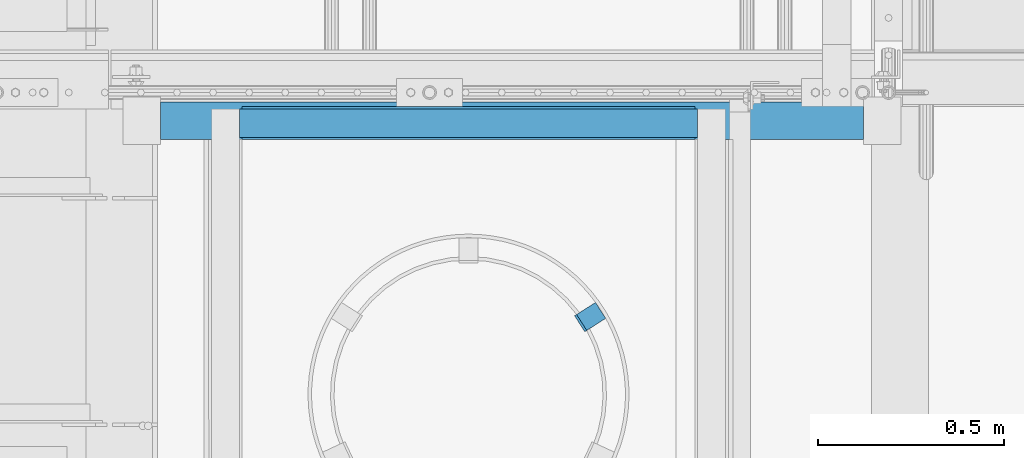
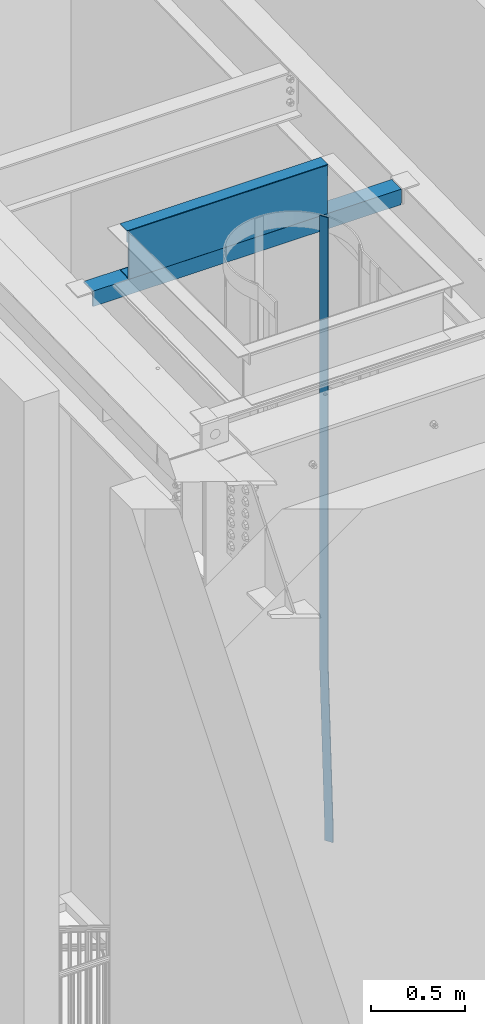
# One storey, part 1084 of 1763: 4 beams, 3 elements without a shape of their own.
"""IFC2X3 building model written with IfcOpenShell, lengths in millimetres."""

from ifc_helpers import new_model, si_unit, frame, origin_with_axes, place, context, subcontext, project, spatial, faceted_brep, material, type_object, element, aggregate, save


model = new_model("IFC2X3")

# Units and contexts
model_context = context("Model", 3, precision=1e-05, world=origin_with_axes())
body_context = subcontext(model_context, "Body", "Model", "MODEL_VIEW")
ifc_project = project(units=[si_unit("LENGTHUNIT", "METRE", prefix="MILLI"), si_unit("AREAUNIT", "SQUARE_METRE"), si_unit("VOLUMEUNIT", "CUBIC_METRE"), si_unit("MASSUNIT", "GRAM", prefix="KILO"), si_unit("TIMEUNIT", "SECOND"), si_unit("PLANEANGLEUNIT", "RADIAN"), si_unit("SOLIDANGLEUNIT", "STERADIAN"), si_unit("THERMODYNAMICTEMPERATUREUNIT", "DEGREE_CELSIUS"), si_unit("LUMINOUSINTENSITYUNIT", "LUMEN")], contexts=[model_context])

# Site, building, storey
site_placement = place(None, origin_with_axes())
site = spatial("IfcSite", under=ifc_project, at=site_placement, CompositionType="ELEMENT")
building_placement = place(site_placement, origin_with_axes())
building = spatial("IfcBuilding", under=site, at=building_placement, Name="Undefined", CompositionType="ELEMENT")
storey_placement = place(building_placement, origin_with_axes())
storey = spatial("IfcBuildingStorey", under=building, at=storey_placement, Name="Undefined", CompositionType="ELEMENT", Elevation=0.0)

# Assembly, beam
assembly_1_placement = place(storey_placement, origin_with_axes())
assembly_1 = element("IfcElementAssembly", 1, at=assembly_1_placement, inside=storey, Name="ANGLE", AssemblyPlace="NOTDEFINED", PredefinedType="RIGID_FRAME")
ifc_material = material(Name="STEEL/A36")
beam_type_1 = type_object("IfcBeamType", Name="L4X4X3/8", PredefinedType="NOTDEFINED")
beam_1_placement = place(assembly_1_placement, frame((-85347.5194165555, 31598.6799583902, 11272.1071573066), z_axis=(0.0, 0.999779834654609, 0.0209829029927513), x_axis=(-1.0, 0.0, 0.0)))
beam_1 = element("IfcBeam", 2, at=beam_1_placement, type_object=beam_type_1, material=ifc_material, Name="ANGLE", ObjectType="L4X4X3/8", context=body_context, shape_type="Brep", body=[
    faceted_brep([(-3.63797880709171e-11, 50.8000000000011, -50.8000000000538), (-1.96450855582952e-10, 50.8000000000393, 50.7999999999374), (1891.39285714286, 50.8000000000102, 50.8000000001084), (1891.39285714286, 50.7999999999211, -50.8000000000138), (0.0, 41.2749999999996, 50.7999999999993), (1891.39285714286, 41.2750000000142, 50.8000000001011), (0.0, 41.2749999999996, -41.2750000000015), (1891.39285714286, 41.2749999999342, -41.2750000000087), (0.0, -50.7999999999993, -41.2750000000015), (1891.39285714286, -50.8000000000029, -41.275000000096), (2.11002770811319e-10, -50.8000000000357, -50.799999999952), (1891.39285714286, -50.800000000012, -50.8000000001048)], [[[0, 1, 2, 3]], [[1, 4, 5, 2]], [[4, 6, 7, 5]], [[6, 8, 9, 7]], [[8, 10, 11, 9]], [[10, 0, 3, 11]], [[5, 7, 9, 11, 3, 2]], [[10, 8, 6, 4, 1, 0]]]),
])
aggregate(assembly_1, [beam_1])

assembly_2_placement = place(storey_placement, origin_with_axes())
assembly_2 = element("IfcElementAssembly", 3, at=assembly_2_placement, inside=storey, Name="BENT_PLATE", AssemblyPlace="NOTDEFINED", PredefinedType="RIGID_FRAME")
beam_type_2 = type_object("IfcBeamType", Name="L3X3X1/4", PredefinedType="NOTDEFINED")
beam_2_placement = place(assembly_2_placement, frame((-85794.287273699, 31591.2752103826, 11597.7774622409), z_axis=(0.0, 1.0, 0.0), x_axis=(-1.0, 0.0, 0.0)))
beam_2 = element("IfcBeam", 4, at=beam_2_placement, type_object=beam_type_2, material=ifc_material, Name="ANGLE", ObjectType="L3X3X1/4", context=body_context, shape_type="Brep", body=[
    faceted_brep([(0.0, 38.0999999999985, -38.1000000000004), (0.0, 38.0999999999985, 38.1000000000004), (1231.90000000002, 38.1000000000004, 38.0999999999985), (1231.90000000002, 38.1000000000004, -38.0999999999985), (0.0, 31.75, 38.1000000000058), (1231.90000000002, 31.75, 38.0999999999985), (0.0, 31.75, -31.75), (1231.90000000002, 31.75, -31.75), (0.0, -38.1000000000004, -31.75), (1231.90000000002, -38.1000000000004, -31.75), (0.0, -38.0999999999985, -38.1000000000004), (1231.90000000002, -38.1000000000004, -38.0999999999985)], [[[0, 1, 2, 3]], [[1, 4, 5, 2]], [[4, 6, 7, 5]], [[6, 8, 9, 7]], [[8, 10, 11, 9]], [[10, 0, 3, 11]], [[5, 7, 9, 11, 3, 2]], [[10, 8, 6, 4, 1, 0]]]),
])

assembly_3_placement = place(storey_placement, origin_with_axes())
assembly_3 = element("IfcElementAssembly", 5, at=assembly_3_placement, inside=storey, Name="LADDER", AssemblyPlace="NOTDEFINED", PredefinedType="RIGID_FRAME")
beam_type_3 = type_object("IfcBeamType", PredefinedType="NOTDEFINED")
beam_3_placement = place(assembly_3_placement, frame((-86057.4167775402, 31085.7714454913, 7620.00000000029), z_axis=(-0.537299608015338, 0.843391446024065, 0.0), x_axis=(0.0, 0.0, 1.0)))
beam_3 = element("IfcBeam", 6, at=beam_3_placement, type_object=beam_type_3, material=ifc_material, Name="PLATE", context=body_context, shape_type="Brep", body=[
    faceted_brep([(0.0, -3.17500000017753, -25.4000000001233), (0.0, -3.17499999987194, 25.4000000001051), (0.0, 3.17500000014843, 25.4000000001197), (0.0, 3.17499999984284, -25.4000000001088), (76.1999969380622, 3.17500000014843, 25.4000000001197), (76.1999969380695, 3.17499999984284, -25.4000000001088), (76.0331158036188, -3.17500000017753, -25.4000000001197), (76.0331158036115, -3.17499999987194, 25.4000000001051), (1225.55004882846, -57.2777259409777, 25.400000000287), (1225.55004882847, -57.2777259412833, -25.3999999999487), (1225.38316769402, -63.6277259413182, -25.3999999999633), (1225.38316769401, -63.6277259410126, 25.4000000002725), (4092.07739257812, -57.2777259409631, 25.4000000002798), (4092.07739257812, -57.2777259412833, -25.399999999956), (4092.07739257812, -63.6277259410126, 25.4000000002652), (4092.07739257812, -63.6277259413182, -25.3999999999705)], [[[0, 1, 2, 3]], [[3, 2, 4, 5]], [[1, 0, 6, 7]], [[5, 4, 8, 9]], [[7, 6, 10, 11]], [[9, 8, 12, 13]], [[8, 4, 2, 1, 7, 11, 14, 12]], [[11, 10, 15, 14]], [[10, 6, 0, 3, 5, 9, 13, 15]], [[14, 15, 13, 12]]]),
])
aggregate(assembly_3, [beam_3])

# Beam
beam_type_4 = type_object("IfcBeamType", PredefinedType="NOTDEFINED")
beam_4_placement = place(assembly_2_placement, frame((-86410.2372736991, 31636.0235822931, 11327.1359914025), z_axis=(1.0, 0.0, 0.0), x_axis=(0.0, -0.999712448072802, -0.0239795990017532)))
beam_4 = element("IfcBeam", 7, at=beam_4_placement, type_object=beam_type_4, material=ifc_material, Name="BENT_PLATE", context=body_context, shape_type="Brep", body=[
    faceted_brep([(-1.94995664060116e-09, -3.17499999999927, -609.600000000006), (-1.94995664060116e-09, -3.17499999999927, 609.600000000006), (1.96087057702243e-09, 3.17500000000291, 609.600000000006), (1.96087057702243e-09, 3.17500000000291, -609.600000000006), (88.9031964237984, 3.17499987854899, 609.600000000006), (88.9031964237984, 3.17499987854899, -609.600000000006), (82.3990556921526, -3.17500011256379, -609.600000000006), (82.3990556921526, -3.17500011256379, 609.600000000006), (81.3724652069359, -310.782115919683, 609.600000000006), (81.3724652069359, -310.782115919683, -609.600000000006), (75.0242911616733, -310.629845466023, 609.600000000006), (75.0242911616733, -310.629845466023, -609.600000000006)], [[[0, 1, 2, 3]], [[3, 2, 4, 5]], [[1, 0, 6, 7]], [[5, 4, 8, 9]], [[4, 2, 1, 7, 10, 8]], [[7, 6, 11, 10]], [[6, 0, 3, 5, 9, 11]], [[10, 11, 9, 8]]]),
])

aggregate(assembly_2, [beam_2, beam_4])

save(model, "model.ifc")
